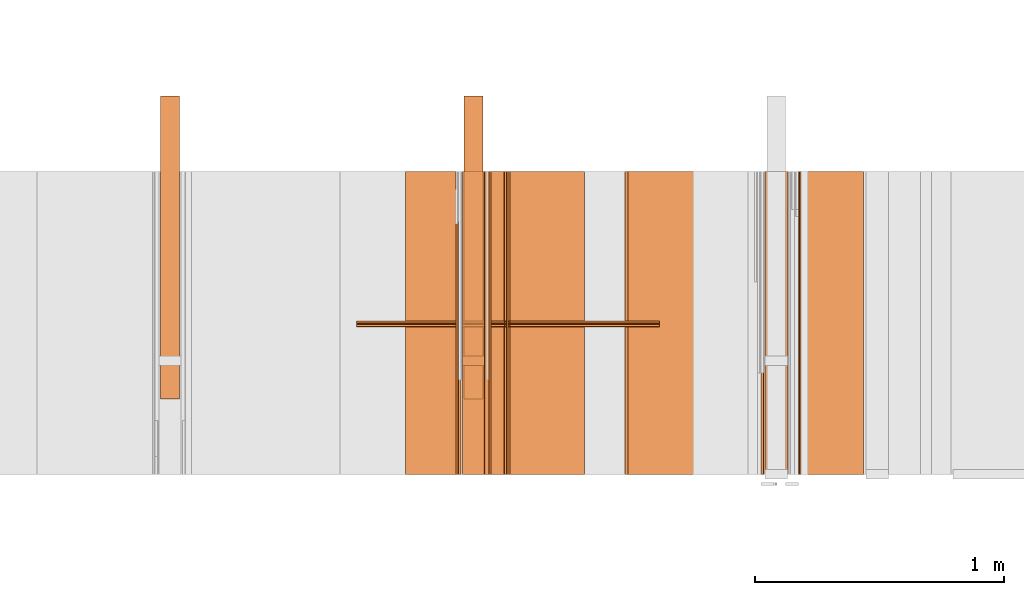
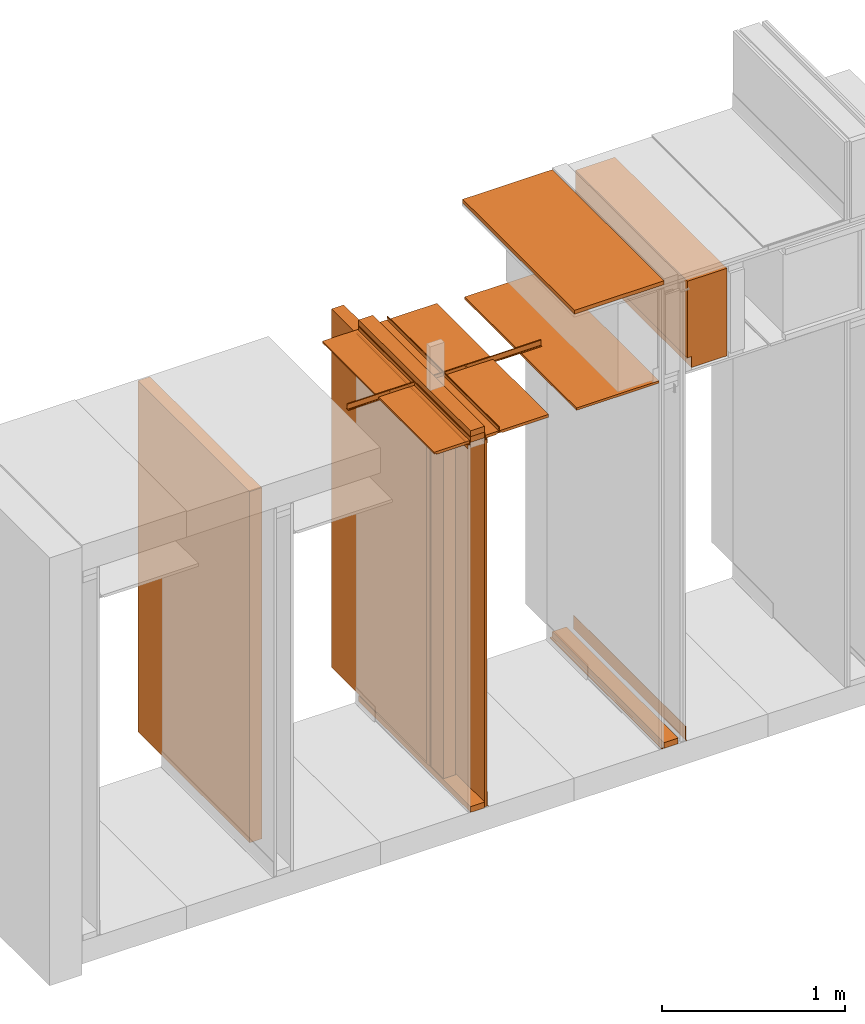
# One storey, part 9 of 38: 24 proxies.
"""IFC4 building model written with IfcOpenShell, lengths in feet."""

from ifc_helpers import new_model, entity, si_unit, converted_unit, frame, origin_with_axes, origin_2d_with_axis, place, context, subcontext, project, spatial, polyline, line, indexed_curve, outline, extrude, material, element, save


model = new_model("IFC4")

# Units and contexts
model_context_1 = context("Model", 3, precision=1e-05, world=origin_with_axes())
plan_context = context("Plan", 2, precision=1e-05, world=origin_2d_with_axis())
model_context_2 = context("Model", 3, precision=1e-05, world=origin_with_axes())
context_of_model_1 = context(None, 3, precision=1e-05, world=origin_with_axes())
context_of_model_2 = context(None, 3, precision=1e-05, world=origin_with_axes())
body_context = subcontext(model_context_2, "Body", "Model", "MODEL_VIEW")
ifc_project = project(units=[converted_unit("PLANEANGLEUNIT", "degree", entity("IfcReal", 0.0174532925199433), si_unit("PLANEANGLEUNIT", "RADIAN"), dimensions=[0, 0, 0, 0, 0, 0, 0]), converted_unit("AREAUNIT", "square foot", entity("IfcReal", 0.09290304), si_unit("AREAUNIT", "SQUARE_METRE"), dimensions=[2, 0, 0, 0, 0, 0, 0]), converted_unit("LENGTHUNIT", "foot", entity("IfcReal", 0.3048), si_unit("LENGTHUNIT", "METRE"), dimensions=[1, 0, 0, 0, 0, 0, 0]), converted_unit("VOLUMEUNIT", "cubic foot", entity("IfcReal", 0.0283168467116885), si_unit("VOLUMEUNIT", "CUBIC_METRE"), dimensions=[3, 0, 0, 0, 0, 0, 0])], contexts=[model_context_1, plan_context, context_of_model_1, context_of_model_2])

# Site, building, storey
site_placement = place(None, origin_with_axes())
site = spatial("IfcSite", under=ifc_project, at=site_placement)
building_placement = place(site_placement, origin_with_axes())
building = spatial("IfcBuilding", under=site, at=building_placement, Name="Building")
storey_placement = place(building_placement, origin_with_axes())
storey = spatial("IfcBuildingStorey", under=building, at=storey_placement, Name="Storey")

# Proxies
proxy_1_placement = place(storey_placement, frame((1383.04162213183, 5.99999987860051, 0.0), z_axis=(4.37113882867379e-08, -0.999999999999999, -8.51092183247426e-15), x_axis=(1.94707183709394e-07, 0.0, 0.999999999999981)))
element("IfcBuildingElementProxy", 1, at=proxy_1_placement, inside=storey, Name="Generic Models 13:Generic Models 1", PredefinedType="COMPLEX", context=body_context, shape_type="SweptSolid", body=[
    extrude(outline(polyline([(-0.0625000007724355, -0.145833333098669), (0.0625000007724355, -0.145833333098669), (0.062500006883476, 0.145833333098669), (-0.0625000007724355, 0.145833333098669), (-0.0625000007724355, -0.145833333098669)])), frame((0.0625000313276381, -0.145833320876588, -4.08491298529716e-07), z_axis=(-1.6389038902582e-14, 1.19209246918217e-07, -1.0), x_axis=(1.0, 1.94707183709397e-07, 0.0)), (5.40078315403036e-10, -5.71617336797559e-11, -1.0), 4.00000000752362),
])
proxy_2_placement = place(storey_placement, frame((1375.06249695625, 2.99999993930026, 0.125000001544871), z_axis=(-1.62920684942944e-07, 0.999999999999987, -1.23001694617954e-14), x_axis=(7.54979012640431e-08, 0.0, -0.999999999999997)))
element("IfcBuildingElementProxy", 2, at=proxy_2_placement, inside=storey, Name="Generic Models 18:Generic Models 1", PredefinedType="COMPLEX", context=body_context, shape_type="SweptSolid", body=[
    extrude(outline(polyline([(-3.83239327453253, -0.12499998932279), (3.83239327453253, -0.12499998932279), (3.83239327453253, 0.125000013766952), (-3.83239327453253, 0.125000025989033), (-3.83239327453253, -0.12499998932279)])), frame((-3.83239327453253, -0.125000282652735, -4.20396346619738e-14), z_axis=(1.23001711558614e-14, 0.0, -1.0), x_axis=(0.999999940395355, 7.49450492776305e-08, 1.23001711558614e-14)), (-2.34202568449859e-09, 1.52774848327653e-09, -1.0), 4.00000000752362),
])
proxy_3_placement = place(storey_placement, frame((1383.52341539278, 5.99999987860051, 8.1138363660477), z_axis=(4.37113882867379e-08, -0.999999999999999, -8.51092183247426e-15), x_axis=(1.94707183709394e-07, 0.0, 0.999999999999981)))
element("IfcBuildingElementProxy", 3, at=proxy_3_placement, inside=storey, Name="Generic Models 21:Generic Models 1", PredefinedType="COMPLEX", context=body_context, shape_type="SweptSolid", body=[
    extrude(outline(polyline([(-0.298457181086065, -1.194856748024), (0.516202525673263, -1.194856748024), (0.516202476784939, 0.717593723629403), (-0.217745344587198, 0.717593674741079), (-0.217745344587198, 0.477263171059566), (-0.298457278862713, 0.477263171059566), (-0.298457181086065, -1.194856748024)])), frame((0.717593723629403, -0.298457107753578, -3.55788801744834e-08), z_axis=(-3.2888513960827e-14, 1.19209303761636e-07, -1.0), x_axis=(2.4004290821722e-07, -1.0, -1.19209289550781e-07)), (3.29755756034444e-09, 5.68858027349961e-09, -1.0), 4.00000000752362),
])
ifc_material_1 = material(Name="WALL BASE AS SCHEDULED")
proxy_4_placement = place(storey_placement, frame((1383.47916089957, 5.99999987860051, 0.0), z_axis=(4.37113882867379e-08, -0.999999999999999, -8.51092183247426e-15), x_axis=(1.94707183709394e-07, 0.0, 0.999999999999981)))
element("IfcBuildingElementProxy", 4, at=proxy_4_placement, inside=storey, material=ifc_material_1, Name="Generic Models 228:Generic Models 1", PredefinedType="COMPLEX", context=body_context, shape_type="SweptSolid", body=[
    extrude(outline(polyline([(0.220647404395689, -6.29889841073551e-10), (0.220442880091705, 0.00356434038693569), (0.218163535311779, 0.00828269806756513), (0.213215401361934, 0.0100073574497083), (-0.0621307594823869, -0.00579188951520919), (-0.0746566692264531, -0.00486853115414599), (-0.0865167811063174, -0.000734690297517212), (-0.0969028489033538, 0.00632791332301642), (-0.105107085793976, 0.0158379745383666), (-0.113815000754955, 0.0101214184931765), (-0.103834498272793, -0.00144763436187376), (-0.0911997814523423, -0.0100393357608477), (-0.0767718836802041, -0.015068177458906), (-0.0615340408201762, -0.0161914508716445), (0.220647404395689, -6.29889841073551e-10)])), frame((0.113048297389755, -0.0126398416918035, -1.50679009951663e-09), z_axis=(-3.19906929180554e-14, 1.19209282445354e-07, -1.0), x_axis=(0.998357832431793, 0.0572855435311794, 6.82893697145914e-09)), (1.19532195252958e-09, -3.91987414749551e-11, -1.0), 4.00000000752362),
])
ifc_material_2 = material(Name="ACOUSTICAL SEALANT", Category="sealant")
proxy_5_placement = place(storey_placement, frame((1382.98955802217, 5.99999987860051, 0.0), z_axis=(4.37113882867379e-08, -0.999999999999999, -8.51092183247426e-15), x_axis=(1.94707183709394e-07, 0.0, 0.999999999999981)))
element("IfcBuildingElementProxy", 5, at=proxy_5_placement, inside=storey, material=ifc_material_2, Name="Generic Models 246:Generic Models 1", PredefinedType="COMPLEX", context=body_context, shape_type="SweptSolid", body=[
    extrude(outline(polyline([(0.0175297320783725, 1.21719171997307e-09), (-0.00760452534631872, 0.0185696447874344), (-0.0101125697065096, 0.00747135049587707), (-0.0199842895564484, 0.00181347361657025), (0.0051499686321229, -0.0167561721257142), (0.0150216861904215, -0.0110982927637972), (0.0175297320783725, 1.21719171997307e-09)])), frame((0.0104166711240596, -0.0171509025657545, -3.9315117507417e-07), z_axis=(1.14723269946382e-12, 1.19208550586336e-07, -1.0), x_axis=(-0.594228446483612, -0.804296314716339, -9.58762740310704e-08)), (-1.04803887790439e-10, 1.77274347978873e-10, -1.0), 4.00000000752362),
])
proxy_6_placement = place(storey_placement, frame((1379.04530122211, 5.99999987860051, 8.2030516909802), z_axis=(4.37113882867379e-08, -0.999999999999999, -8.51092183247426e-15), x_axis=(1.94707183709394e-07, 0.0, 0.999999999999981)))
element("IfcBuildingElementProxy", 6, at=proxy_6_placement, inside=storey, Name="Generic Models 250:Generic Models 1", PredefinedType="COMPLEX", context=body_context, shape_type="SweptSolid", body=[
    extrude(outline(polyline([(-0.062500006883476, -0.145833320876588), (0.0625000007724355, -0.145833320876588), (0.0625000007724355, 0.14583334532075), (-0.0625000007724355, 0.14583334532075), (-0.062500006883476, -0.145833320876588)])), frame((0.0625000313276381, -0.145833333098669, -1.73846880315148e-08), z_axis=(-3.2778077805164e-14, 1.19209289550781e-07, -1.0), x_axis=(-1.0, -1.9555329799914e-07, 0.0)), (-5.09230324574617e-10, 4.3999508897441e-11, -1.0), 4.00000000752362),
])
proxy_7_placement = place(storey_placement, frame((1381.23439678683, 5.99999987860051, 8.01041683187009), z_axis=(4.37113882867379e-08, -0.999999999999999, -8.51092183247426e-15), x_axis=(1.94707183709394e-07, 0.0, 0.999999999999981)))
element("IfcBuildingElementProxy", 7, at=proxy_7_placement, inside=storey, Name="Generic Models 372:Generic Models 1", PredefinedType="COMPLEX", context=body_context, shape_type="SweptSolid", body=[
    extrude(outline(polyline([(-0.0260416674977682, -0.851562544899037), (0.0260416674977682, -0.851562544899037), (0.0260416644422479, 0.851562544899037), (-0.0260416674977682, 0.851562544899037), (-0.0260416674977682, -0.851562544899037)])), frame((0.0260418324958621, -0.851562544899037, -1.01514165985469e-07), z_axis=(0.0, 1.19209289550781e-07, -1.0), x_axis=(1.0, 1.94707169498542e-07, -8.51092267950722e-15)), (-2.01841821034776e-10, 4.27915214373797e-09, -1.0), 4.00000000752362),
])
proxy_8_placement = place(storey_placement, frame((1381.1927454991, 5.99999987860051, 10.1250003329099), z_axis=(4.37113882867379e-08, -0.999999999999999, -8.51092183247426e-15), x_axis=(1.94707183709394e-07, 0.0, 0.999999999999981)))
element("IfcBuildingElementProxy", 8, at=proxy_8_placement, inside=storey, Name="Generic Models 385:Generic Models 1", PredefinedType="COMPLEX", context=body_context, shape_type="SweptSolid", body=[
    extrude(outline(polyline([(-0.0416666692186372, -0.92447918700421), (0.0416666692186372, -0.92447918700421), (0.0416666692186372, 0.92447918700421), (-0.0416666692186372, 0.92447918700421), (-0.0416666692186372, -0.92447918700421)])), frame((0.0416668494943324, -0.92447918700421, -1.10206507087256e-07), z_axis=(0.0, 1.19209289550781e-07, -1.0), x_axis=(1.0, 1.94707169498542e-07, -8.51092267950722e-15)), (6.82104650540083e-11, 5.03972774623662e-09, -1.0), 4.00000000752362),
])
proxy_9_placement = place(storey_placement, frame((1379.06612686598, 2.99999993930026, 0.125000001544871), z_axis=(0.0, 0.0, 1.0), x_axis=(-1.62920684942944e-07, 0.999999999999987, 0.0)))
element("IfcBuildingElementProxy", 9, at=proxy_9_placement, inside=storey, Name="Generic Models 386:Generic Models 1", PredefinedType="COMPLEX", context=body_context, shape_type="SweptSolid", body=[
    extrude(outline(polyline([(-2.00000002471794, -0.125000001544871), (2.00000002471794, -0.125000001544871), (2.00000002471794, 0.125000001544871), (-2.00000002471794, 0.125000001544871), (-2.00000002471794, -0.125000001544871)])), frame((2.00000002471794, -0.125000001544871, 0.0), z_axis=(0.0, 0.0, -1.0), x_axis=(-1.0, 0.0, 0.0)), (0.0, 0.0, -1.0), 7.82805155106246),
])
proxy_10_placement = place(storey_placement, frame((1379.04530122211, 5.99999987860051, 0.0), z_axis=(4.37113882867379e-08, -0.999999999999999, -8.51092183247426e-15), x_axis=(1.94707183709394e-07, 0.0, 0.999999999999981)))
element("IfcBuildingElementProxy", 10, at=proxy_10_placement, inside=storey, Name="Generic Models 412:Generic Models 1", PredefinedType="COMPLEX", context=body_context, shape_type="SweptSolid", body=[
    extrude(outline(polyline([(-0.0625000007724355, -0.145833333098669), (0.0625000007724355, -0.145833333098669), (0.062500006883476, 0.145833333098669), (-0.0625000007724355, 0.145833333098669), (-0.0625000007724355, -0.145833333098669)])), frame((0.0625000313276381, -0.145833320876588, -1.73846880315148e-08), z_axis=(-3.2778077805164e-14, 1.19209289550781e-07, -1.0), x_axis=(1.0, 1.94707183709397e-07, -8.51092267950722e-15)), (5.40069822196898e-10, -5.72200134496548e-11, -1.0), 4.00000000752362),
])
proxy_11_placement = place(storey_placement, frame((1379.38912459246, 5.99999987860051, 0.0), z_axis=(4.37113882867379e-08, -0.999999999999999, -8.51092183247426e-15), x_axis=(1.94707183709394e-07, 0.0, 0.999999999999981)))
element("IfcBuildingElementProxy", 11, at=proxy_11_placement, inside=storey, material=ifc_material_1, Name="Generic Models 415:Generic Models 1", PredefinedType="COMPLEX", context=body_context, shape_type="SweptSolid", body=[
    extrude(outline(polyline([(-0.213438576561572, 0.00222319596675603), (0.0623605162726613, 0.00222319596675603), (0.0748129590876459, 0.000583802452912857), (0.0864167861503566, -0.00422266024724627), (0.0963812104849208, -0.0118686360175039), (0.104027191602339, -0.0218330626437084), (0.113048285167674, -0.0166247312830189), (0.103746902618039, -0.00450293968304542), (0.0916251159832859, 0.00479843828330926), (0.0775089912761853, 0.0106455295913782), (0.0623605162726613, 0.0126398630804453), (-0.220285068581423, 0.0126398630804453), (-0.220285068581423, 0.0090696595320747), (-0.21827976730239, 0.00422847872169742), (-0.213438576561572, 0.00222319596675603)])), frame((0.113048285167674, -0.0126398409279234, -3.92613419174284e-07), z_axis=(8.52252906376368e-14, 1.19209985882662e-07, -1.0), x_axis=(-1.0, -1.93878832988048e-07, 0.0)), (6.12672523825353e-10, 1.03401905093836e-10, -1.0), 4.00000000752362),
])
proxy_12_placement = place(storey_placement, frame((1379.04530122211, 3.44270835398376, 0.125000001544871), z_axis=(0.0, 0.0, 1.0), x_axis=(1.0, 0.0, 0.0)))
element("IfcBuildingElementProxy", 12, at=proxy_12_placement, inside=storey, Name="Generic Models 419:Generic Models 65", PredefinedType="COMPLEX", context=body_context, shape_type="SweptSolid", body=[
    extrude(outline(polyline([(-0.145833333098669, -0.0625000007724355), (0.145833333098669, -0.0625000007724355), (0.145833333098669, 0.0625000007724355), (-0.145833333098669, 0.0625000007724355), (-0.145833333098669, -0.0625000007724355)])), frame((0.145833333098669, 0.0625000007724355, 0.0), z_axis=(0.0, 0.0, -1.0), x_axis=(-1.0, 0.0, 0.0)), (0.0, 0.0, -1.0), 7.82805155106246),
])
ifc_material_3 = material(Category="sand")
proxy_13_placement = place(storey_placement, frame((1379.33696035951, 5.99999987860051, 0.0208333330815585), z_axis=(4.37113882867379e-08, -0.999999999999999, -8.51092183247426e-15), x_axis=(1.94707183709394e-07, 0.0, 0.999999999999981)))
element("IfcBuildingElementProxy", 13, at=proxy_13_placement, inside=storey, material=ifc_material_3, Name="Generic Models 432:Generic Models 1", PredefinedType="COMPLEX", context=body_context, shape_type="SweptSolid", body=[
    extrude(outline(polyline([(-4.00429713757332, -0.0260416674977682), (4.00429713757332, -0.0260416674977682), (4.00429713757332, 0.0260416674977682), (-4.00429713757332, 0.0260416674977682), (-4.00429713757332, -0.0260416674977682)])), frame((4.00429713757332, -0.0260408883401024, -3.94211021364806e-07), z_axis=(-2.90081645498968e-14, 1.19209147442234e-07, -1.0), x_axis=(1.0, 1.94707183709397e-07, -5.82168836318138e-15)), (-1.26761612317949e-09, 8.30831445308711e-11, -1.0), 4.00000000752362),
])
proxy_14_placement = place(storey_placement, frame((1379.59768140097, 5.99999987860051, 8.07805167721325), z_axis=(4.37113882867379e-08, -0.999999999999999, -8.51092183247426e-15), x_axis=(1.94707183709394e-07, 0.0, 0.999999999999981)))
element("IfcBuildingElementProxy", 14, at=proxy_14_placement, inside=storey, Name="Generic Models 565:Generic Models 1", PredefinedType="COMPLEX", context=body_context, shape_type="SweptSolid", body=[
    extrude(outline(indexed_curve([(0.0296970291596072, 0.00584526601665485), (0.0310626083843195, 0.00603154810081942), (0.0626632511087759, 0.0014601720208571), (0.0643079704421712, 0.000482393316240135), (0.0647795777719008, -0.00137198206741275), (0.0625126995146275, -0.0170422039603389), (0.0615349085879295, -0.0186869355158152), (0.0596805194544354, -0.0191585306234638), (0.0280798858965397, -0.0145871407936603), (0.0268230801374893, -0.0140215089945538), (0.0260570398201858, -0.0128758294517639), (0.0234390624243952, -0.00470634757631563), (-0.0547061508076554, 0.00659821266577313), (-0.0569313823238132, 0.00603231159894387), (-0.0581047204359779, 0.00405863991980086), (-0.0618188275302958, -0.0216159434852207), (-0.0612498224368246, -0.0282138154604851), (-0.063385453876939, -0.0304752946134627), (-0.0653873390843236, -0.0280945523937778), (-0.0547449498038905, 0.0454730346916229), (-0.052150489219765, 0.0471888804255821), (-0.0507432907536196, 0.0444148408048578), (-0.0531587436834345, 0.0382487337029199), (-0.0568728507777524, 0.0125741541172986), (-0.0563069378707822, 0.0103488813516173), (-0.0543332734484998, 0.00917554858661308), (0.0238125019992782, -0.00212908727960206), (0.0286377505631506, 0.00496365217335542), (0.0301359515891379, 0.00484996925051913), (0.0636623756779148, 1.22221276552383e-08), (0.0610525213827298, -0.0180413728345215), (0.0275254770233406, -0.0131913027518338), (0.024430948466043, -0.0035348496512263)], segments=[line(7, 6), line(6, 5), line(5, 4), line(4, 3), line(3, 2), line(2, 1), line(1, 28), line(28, 27), line(27, 26), line(26, 25), line(25, 24), line(24, 23), line(23, 22), line(22, 21), line(21, 20), line(20, 19), line(19, 18), line(18, 17), line(17, 16), line(16, 15), line(15, 14), line(14, 13), line(13, 12), line(12, 11), line(11, 10), line(10, 9), line(9, 8), line(8, 7)], self_intersect=False), holes=[indexed_curve([(0.0296970291596072, 0.00584526601665485), (0.0310626083843195, 0.00603154810081942), (0.0626632511087759, 0.0014601720208571), (0.0643079704421712, 0.000482393316240135), (0.0647795777719008, -0.00137198206741275), (0.0625126995146275, -0.0170422039603389), (0.0615349085879295, -0.0186869355158152), (0.0596805194544354, -0.0191585306234638), (0.0280798858965397, -0.0145871407936603), (0.0268230801374893, -0.0140215089945538), (0.0260570398201858, -0.0128758294517639), (0.0234390624243952, -0.00470634757631563), (-0.0547061508076554, 0.00659821266577313), (-0.0569313823238132, 0.00603231159894387), (-0.0581047204359779, 0.00405863991980086), (-0.0618188275302958, -0.0216159434852207), (-0.0612498224368246, -0.0282138154604851), (-0.063385453876939, -0.0304752946134627), (-0.0653873390843236, -0.0280945523937778), (-0.0547449498038905, 0.0454730346916229), (-0.052150489219765, 0.0471888804255821), (-0.0507432907536196, 0.0444148408048578), (-0.0531587436834345, 0.0382487337029199), (-0.0568728507777524, 0.0125741541172986), (-0.0563069378707822, 0.0103488813516173), (-0.0543332734484998, 0.00917554858661308), (0.0238125019992782, -0.00212908727960206), (0.0286377505631506, 0.00496365217335542), (0.0301359515891379, 0.00484996925051913), (0.0636623756779148, 1.22221276552383e-08), (0.0610525213827298, -0.0180413728345215), (0.0275254770233406, -0.0131913027518338), (0.024430948466043, -0.0035348496512263)], segments=[line(31, 32), line(32, 33), line(33, 29), line(29, 30), line(30, 31)], self_intersect=False)]), frame((0.0606913649992836, -0.0392497557501389, -3.95785544903478e-07), z_axis=(4.56824942457468e-12, 1.19214490723607e-07, -1.0), x_axis=(0.989697992801666, -0.143170446157455, -1.70668190691003e-08)), (-5.47911105375221e-10, -1.58496715751966e-10, -1.0), 4.00000000752362),
])
ifc_material_4 = material(Name="J BEAD DRYWALL TRIM", Category="poche")
proxy_15_placement = place(storey_placement, frame((1379.33335592115, 5.99999987860051, 7.94737514235529), z_axis=(4.37113882867379e-08, -0.999999999999999, -8.51092183247426e-15), x_axis=(1.94707183709394e-07, 0.0, 0.999999999999981)))
element("IfcBuildingElementProxy", 15, at=proxy_15_placement, inside=storey, material=ifc_material_4, Name="Generic Models 568:Generic Models 1", PredefinedType="COMPLEX", context=body_context, shape_type="SweptSolid", body=[
    extrude(outline(polyline([(-0.0344678146026422, -0.0297083376400818), (0.0524882097628329, -0.0297083376400818), (0.0524882097628329, -0.0260416705532884), (-0.0312586138978248, -0.0260416705532884), (-0.0312586138978248, 0.0260416644422479), (0.0131548778948391, 0.0260416644422479), (0.0133215427750678, 0.0297083315290413), (-0.0344678146026422, 0.0297083315290413), (-0.0344678146026422, -0.0297083376400818)])), frame((0.0524882158738735, -0.0297083193069603, -3.94648117043793e-07), z_axis=(-2.40435752904555e-12, 1.19208344528943e-07, -1.0), x_axis=(-1.0, -2.1083209844619e-07, 0.0)), (3.81318622511007e-11, 3.32015331894198e-10, -1.0), 4.00000000752362),
])
proxy_16_placement = place(storey_placement, frame((1379.04530122211, 5.99999987860051, 8.07805167721325), z_axis=(4.37113882867379e-08, -0.999999999999999, -8.51092183247426e-15), x_axis=(1.94707183709394e-07, 0.0, 0.999999999999981)))
element("IfcBuildingElementProxy", 16, at=proxy_16_placement, inside=storey, Name="Generic Models 569:Generic Models 1", PredefinedType="COMPLEX", context=body_context, shape_type="SweptSolid", body=[
    extrude(outline(polyline([(-0.145833333098669, -0.0625000007724355), (0.145833333098669, -0.0625000007724355), (0.145833333098669, 0.0625000007724355), (-0.145833333098669, 0.062500006883476), (-0.145833333098669, -0.0625000007724355)])), frame((0.0625000313276381, -0.145833320876588, -1.73846880315148e-08), z_axis=(-3.2778077805164e-14, 1.19209289550781e-07, -1.0), x_axis=(-1.94707197920252e-07, 1.0, 1.19209289550781e-07)), (5.72196491577248e-11, 5.40068767485025e-10, -1.0), 4.00000000752362),
])
proxy_17_placement = place(storey_placement, frame((1378.99323711245, 5.99999987860051, 8.03645827325936), z_axis=(4.37113882867379e-08, -0.999999999999999, -8.51092183247426e-15), x_axis=(1.94707183709394e-07, 0.0, 0.999999999999981)))
element("IfcBuildingElementProxy", 17, at=proxy_17_placement, inside=storey, material=ifc_material_2, Name="Generic Models 570:Generic Models 1", PredefinedType="COMPLEX", context=body_context, shape_type="SweptSolid", body=[
    extrude(outline(polyline([(0.0200664036078599, 9.49803628864403e-10), (-0.00664321054873152, 0.0162221848221589), (-0.0159632111471782, 0.00969531626276809), (-0.0174579991570373, -0.00158422404265867), (0.00925161041627367, -0.0178064079099675), (0.010746400717773, -0.00652686703163065), (0.0200664036078599, 9.49803628864403e-10)])), frame((0.0104166703601796, -0.0171509010379943, -2.04454727426466e-09), z_axis=(-1.8821786983798e-14, 1.19209317972491e-07, -1.0), x_axis=(0.519109785556793, 0.854707658290863, 1.01889078507611e-07)), (-8.89110868262932e-11, -1.99414706969492e-10, -1.0), 4.00000000752362),
])
ifc_material_5 = material(Name="CEILING TRACK AS SCHEDULED", Category="poche")
proxy_18_placement = place(storey_placement, frame((1379.33696035951, 5.99999987860051, 8.05729173925605), z_axis=(4.37113882867379e-08, -0.999999999999999, -8.51092183247426e-15), x_axis=(1.94707183709394e-07, 0.0, 0.999999999999981)))
element("IfcBuildingElementProxy", 18, at=proxy_18_placement, inside=storey, material=ifc_material_5, Name="Generic Models 572:Generic Models 1", PredefinedType="COMPLEX", context=body_context, shape_type="SweptSolid", body=[
    extrude(outline(polyline([(0.0867708292826423, -1.49860712203641e-09), (0.0849992875254217, 0.00489779119807591), (-0.0276499528076079, -0.03584767532904), (-0.0542230852769585, 0.037619220141781), (-0.0591208825860749, 0.0358476783845603), (-0.0307762053039834, -0.0425170113398569), (0.0867708292826423, -1.49860712203641e-09)])), frame((0.0434027852739875, -0.0295138812753472, -3.94624898521325e-07), z_axis=(0.0, 1.19209815352406e-07, -1.0), x_axis=(0.940376162528992, 0.340136259794235, 4.0547099899868e-08)), (-1.29517271907353e-10, -1.93627558431331e-10, -1.0), 4.00000000752362),
])
ifc_material_6 = material(Name="EXISTING ACOUSTICAL TILE", Category="poche")
proxy_19_placement = place(storey_placement, frame((1379.35648440063, 5.99999987860051, 8.06249971464863), z_axis=(4.37113882867379e-08, -0.999999999999999, -8.51092183247426e-15), x_axis=(1.94707183709394e-07, 0.0, 0.999999999999981)))
element("IfcBuildingElementProxy", 19, at=proxy_19_placement, inside=storey, material=ifc_material_6, Name="Generic Models 573:Generic Models 1", PredefinedType="COMPLEX", context=body_context, shape_type="SweptSolid", body=[
    extrude(outline(polyline([(0.0648316988364605, 1.52775748817601e-09), (0.056761642062445, 0.0265119334541046), (-0.164585280919012, 0.0383837571431176), (-0.167932627805731, -0.0240265457766263), (0.104485959635945, -0.0386375730999029), (0.10643857152365, -0.00223155797085189), (0.0648316988364605, 1.52775748817601e-09)])), frame((0.0295139240526308, -0.166404782122201, -4.1094360343887e-07), z_axis=(-6.03470832333253e-13, 1.19209332183345e-07, -1.0), x_axis=(-0.0535573028028011, -0.998564839363098, -1.19038290335993e-07)), (2.012843003385e-09, 2.74091055407766e-10, -1.0), 4.00000000752362),
])
proxy_20_placement = place(storey_placement, frame((1379.64473934624, 5.99999987860051, 8.06249971464863), z_axis=(4.37113882867379e-08, -0.999999999999999, -8.51092183247426e-15), x_axis=(1.94707183709394e-07, 0.0, 0.999999999999981)))
element("IfcBuildingElementProxy", 20, at=proxy_20_placement, inside=storey, material=ifc_material_6, Name="Generic Models 574:Generic Models 1", PredefinedType="COMPLEX", context=body_context, shape_type="SweptSolid", body=[
    extrude(outline(polyline([(-0.0329862356068581, -0.659830506470573), (0.0295137621100571, -0.659830506470573), (0.0295139515523131, 0.301973107136454), (0.00347228405454497, 0.311451502085671), (0.00347229322110574, 0.353118165193267), (-0.0329860400535616, 0.353118165193267), (-0.0329862356068581, -0.659830506470573)])), frame((0.0295139607188739, -0.353118165193267, -4.33201587754251e-07), z_axis=(4.87306592647507e-13, 1.19209303761636e-07, -1.0), x_axis=(-1.0, 0.0, 0.0)), (0.0, -3.01151925619081e-09, -1.0), 4.00000000752362),
])
proxy_21_placement = place(storey_placement, frame((1378.29477705668, 5.99999987860051, 8.06249971464863), z_axis=(4.37113882867379e-08, -0.999999999999999, -8.51092183247426e-15), x_axis=(1.94707183709394e-07, 0.0, 0.999999999999981)))
element("IfcBuildingElementProxy", 21, at=proxy_21_placement, inside=storey, material=ifc_material_6, Name="Generic Models 575:Generic Models 1", PredefinedType="COMPLEX", context=body_context, shape_type="SweptSolid", body=[
    extrude(outline(polyline([(0.210121185995462, 2.22077733135034e-09), (0.215847768730379, 0.0271148456558781), (0.257101349943266, 0.032967398324468), (0.25198037132347, 0.0690642910523052), (-0.471914592846798, -0.0336330739678595), (-0.463135765371673, -0.0955134549537512), (0.210121185995462, 2.22077733135034e-09)])), frame((0.0295139423857524, -0.259183112561233, -4.22003639382244e-07), z_axis=(0.0, 1.19209261129072e-07, -1.0), x_axis=(-0.140461504459381, 0.990086138248444, 1.18027550399802e-07)), (4.49586146089587e-09, -8.24930679321767e-10, -1.0), 4.00000000752362),
])
proxy_22_placement = place(storey_placement, frame((1378.98963267409, 5.99999987860051, 7.94737514235529), z_axis=(4.37113882867379e-08, -0.999999999999999, -8.51092183247426e-15), x_axis=(1.94707183709394e-07, 0.0, 0.999999999999981)))
element("IfcBuildingElementProxy", 22, at=proxy_22_placement, inside=storey, material=ifc_material_4, Name="Generic Models 582:Generic Models 1", PredefinedType="COMPLEX", context=body_context, shape_type="SweptSolid", body=[
    extrude(outline(polyline([(-0.034467811547122, -0.0297083376400818), (0.013321545830588, -0.0297083376400818), (0.0131548778948391, -0.0260416705532884), (-0.0312586108423046, -0.0260416705532884), (-0.0312586138978248, 0.0260416613867277), (0.0524882097628329, 0.0260416674977682), (0.0524882097628329, 0.0297083345845615), (-0.0344678146026422, 0.029708328473521), (-0.034467811547122, -0.0297083376400818)])), frame((0.0524882158738735, -0.0297083223624805, -3.54150945956249e-09), z_axis=(-5.78297379059088e-14, 1.19209275339927e-07, -1.0), x_axis=(-0.999999940395355, -2.55749000643846e-07, 1.52438283350376e-14)), (3.71754016459391e-10, -2.56443311030807e-10, -1.0), 4.00000000752362),
])
proxy_23_placement = place(storey_placement, frame((1378.96199864665, 5.99999987860051, 8.05729173925605), z_axis=(4.37113882867379e-08, -0.999999999999999, -8.51092183247426e-15), x_axis=(1.94707183709394e-07, 0.0, 0.999999999999981)))
element("IfcBuildingElementProxy", 23, at=proxy_23_placement, inside=storey, material=ifc_material_5, Name="Generic Models 588:Generic Models 1", PredefinedType="COMPLEX", context=body_context, shape_type="SweptSolid", body=[
    extrude(outline(polyline([(0.0851402753411628, 1.0642824475317e-15), (0.0866271281649121, 0.0049915956699942), (-0.0331710823603815, 0.0406761581611054), (-0.056960794761816, -0.0391893236704777), (-0.0519691990918218, -0.0406761795497472), (-0.0296663486806974, 0.0341977096673619), (0.0851402753411628, 1.0642824475317e-15)])), frame((0.0434027883295077, -0.0538194449398461, -6.41577925228204e-09), z_axis=(0.0, 1.19209261129072e-07, -1.0), x_axis=(0.958385765552521, -0.285476326942444, -3.4031454987371e-08)), (-4.20733725636779e-10, 1.42574785311211e-10, -1.0), 4.00000000752362),
])
proxy_24_placement = place(storey_placement, frame((1377.64737987769, 3.95033928978787, 8.07805167721325), z_axis=(0.999999999999928, 3.2584136988587e-07, -1.94707183709383e-07), x_axis=(1.94707183709394e-07, 0.0, 0.999999999999981)))
element("IfcBuildingElementProxy", 24, at=proxy_24_placement, inside=storey, Name="Generic Models 565:Generic Models 1", PredefinedType="COMPLEX", context=body_context, shape_type="SweptSolid", body=[
    extrude(outline(indexed_curve([(0.0296970291596072, 0.00584526601665485), (0.0310626083843195, 0.00603154810081942), (0.0626632511087759, 0.0014601720208571), (0.0643079704421712, 0.000482393316240135), (0.0647795777719008, -0.00137198206741275), (0.0625126995146275, -0.0170422039603389), (0.0615349085879295, -0.0186869355158152), (0.0596805194544354, -0.0191585306234638), (0.0280798858965397, -0.0145871407936603), (0.0268230801374893, -0.0140215089945538), (0.0260570398201858, -0.0128758294517639), (0.0234390624243952, -0.00470634757631563), (-0.0547061508076554, 0.00659821266577313), (-0.0569313823238132, 0.00603231159894387), (-0.0581047204359779, 0.00405863991980086), (-0.0618188275302958, -0.0216159434852207), (-0.0612498224368246, -0.0282138154604851), (-0.063385453876939, -0.0304752946134627), (-0.0653873390843236, -0.0280945523937778), (-0.0547449498038905, 0.0454730346916229), (-0.052150489219765, 0.0471888804255821), (-0.0507432907536196, 0.0444148408048578), (-0.0531587436834345, 0.0382487337029199), (-0.0568728507777524, 0.0125741541172986), (-0.0563069378707822, 0.0103488813516173), (-0.0543332734484998, 0.00917554858661308), (0.0238125019992782, -0.00212908727960206), (0.0286377505631506, 0.00496365217335542), (0.0301359515891379, 0.00484996925051913), (0.0636623756779148, 1.22221276552383e-08), (0.0610525213827298, -0.0180413728345215), (0.0275254770233406, -0.0131913027518338), (0.024430948466043, -0.0035348496512263)], segments=[line(7, 6), line(6, 5), line(5, 4), line(4, 3), line(3, 2), line(2, 1), line(1, 28), line(28, 27), line(27, 26), line(26, 25), line(25, 24), line(24, 23), line(23, 22), line(22, 21), line(21, 20), line(20, 19), line(19, 18), line(18, 17), line(17, 16), line(16, 15), line(15, 14), line(14, 13), line(13, 12), line(12, 11), line(11, 10), line(10, 9), line(9, 8), line(8, 7)], self_intersect=False), holes=[indexed_curve([(0.0296970291596072, 0.00584526601665485), (0.0310626083843195, 0.00603154810081942), (0.0626632511087759, 0.0014601720208571), (0.0643079704421712, 0.000482393316240135), (0.0647795777719008, -0.00137198206741275), (0.0625126995146275, -0.0170422039603389), (0.0615349085879295, -0.0186869355158152), (0.0596805194544354, -0.0191585306234638), (0.0280798858965397, -0.0145871407936603), (0.0268230801374893, -0.0140215089945538), (0.0260570398201858, -0.0128758294517639), (0.0234390624243952, -0.00470634757631563), (-0.0547061508076554, 0.00659821266577313), (-0.0569313823238132, 0.00603231159894387), (-0.0581047204359779, 0.00405863991980086), (-0.0618188275302958, -0.0216159434852207), (-0.0612498224368246, -0.0282138154604851), (-0.063385453876939, -0.0304752946134627), (-0.0653873390843236, -0.0280945523937778), (-0.0547449498038905, 0.0454730346916229), (-0.052150489219765, 0.0471888804255821), (-0.0507432907536196, 0.0444148408048578), (-0.0531587436834345, 0.0382487337029199), (-0.0568728507777524, 0.0125741541172986), (-0.0563069378707822, 0.0103488813516173), (-0.0543332734484998, 0.00917554858661308), (0.0238125019992782, -0.00212908727960206), (0.0286377505631506, 0.00496365217335542), (0.0301359515891379, 0.00484996925051913), (0.0636623756779148, 1.22221276552383e-08), (0.0610525213827298, -0.0180413728345215), (0.0275254770233406, -0.0131913027518338), (0.024430948466043, -0.0035348496512263)], segments=[line(31, 32), line(32, 33), line(33, 29), line(29, 30), line(30, 31)], self_intersect=False)]), frame((0.0606913649992836, -0.0392497557501389, -3.95785544903478e-07), z_axis=(4.56824942457468e-12, 1.19214490723607e-07, -1.0), x_axis=(0.989697992801666, -0.143170446157455, -1.70668190691003e-08)), (-5.47911105375221e-10, -1.58496715751966e-10, -1.0), 4.00000000752362),
])

save(model, "model.ifc")
